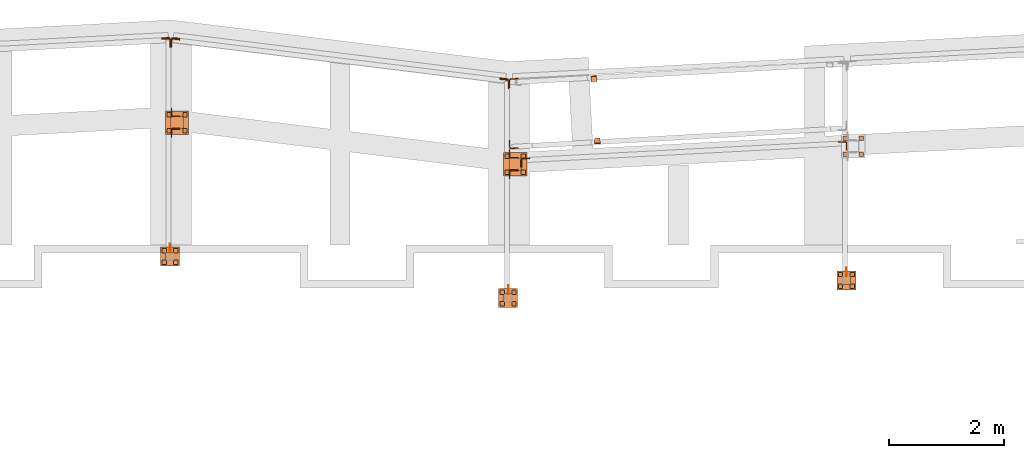
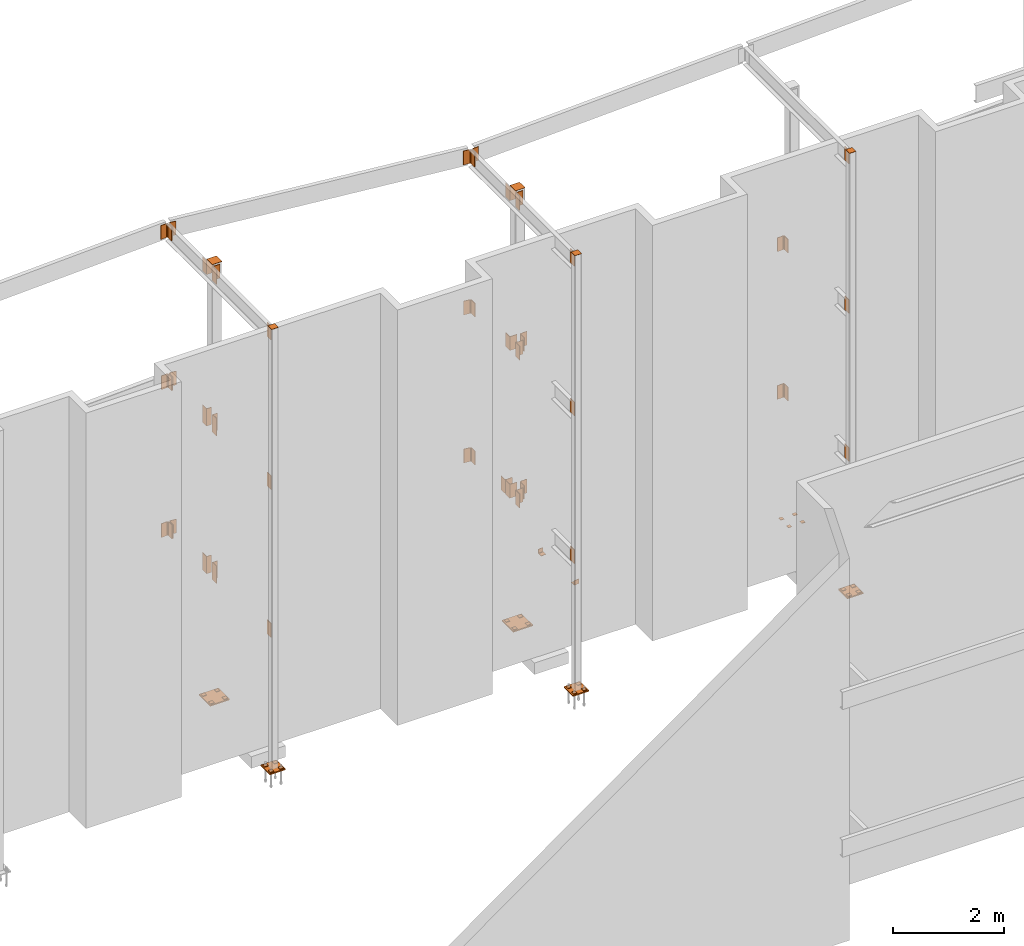
# One storey, part 9 of 89: 72 proxies.
"""IFC4 building model written with IfcOpenShell, lengths in feet."""

from ifc_helpers import new_model, entity, si_unit, converted_unit, derived_unit, direction, frame, origin, origin_2d_with_axis, place, context, subcontext, project, spatial, polyline, rectangle, outline, extrude, source, transform, mapped, material, type_object, type_shapes, element, save


model = new_model("IFC4")

# Units and contexts
model_context = context("Model", 3, precision=0.0001, world=origin(), true_north=direction((6.12303176911189e-17, 1.0)))
body_context = subcontext(model_context, "Body", "Model", "MODEL_VIEW")
ifc_project = project(units=[converted_unit("LENGTHUNIT", "FOOT", entity("IfcRatioMeasure", 0.3048), si_unit("LENGTHUNIT", "METRE"), dimensions=[1, 0, 0, 0, 0, 0, 0]), converted_unit("AREAUNIT", "SQUARE FOOT", entity("IfcRatioMeasure", 0.09290304), si_unit("AREAUNIT", "SQUARE_METRE"), dimensions=[2, 0, 0, 0, 0, 0, 0]), converted_unit("VOLUMEUNIT", "CUBIC FOOT", entity("IfcRatioMeasure", 0.028316846592), si_unit("VOLUMEUNIT", "CUBIC_METRE"), dimensions=[3, 0, 0, 0, 0, 0, 0]), si_unit("PLANEANGLEUNIT", "RADIAN"), si_unit("MASSUNIT", "GRAM", prefix="KILO"), derived_unit("MASSDENSITYUNIT", [(si_unit("MASSUNIT", "GRAM", prefix="KILO"), 1), (si_unit("LENGTHUNIT", "METRE"), -3)]), derived_unit("MOMENTOFINERTIAUNIT", [(si_unit("LENGTHUNIT", "METRE"), 4)]), si_unit("TIMEUNIT", "SECOND"), si_unit("FREQUENCYUNIT", "HERTZ"), si_unit("THERMODYNAMICTEMPERATUREUNIT", "DEGREE_CELSIUS"), derived_unit("THERMALTRANSMITTANCEUNIT", [(si_unit("MASSUNIT", "GRAM", prefix="KILO"), 1), (si_unit("THERMODYNAMICTEMPERATUREUNIT", "KELVIN"), -1), (si_unit("TIMEUNIT", "SECOND"), -3)]), derived_unit("VOLUMETRICFLOWRATEUNIT", [(si_unit("LENGTHUNIT", "METRE"), 3), (si_unit("TIMEUNIT", "SECOND"), -1)]), si_unit("ELECTRICCURRENTUNIT", "AMPERE"), si_unit("ELECTRICVOLTAGEUNIT", "VOLT"), si_unit("POWERUNIT", "WATT"), si_unit("FORCEUNIT", "NEWTON"), si_unit("ILLUMINANCEUNIT", "LUX"), si_unit("LUMINOUSFLUXUNIT", "LUMEN"), si_unit("LUMINOUSINTENSITYUNIT", "CANDELA"), derived_unit("USERDEFINED", [(si_unit("MASSUNIT", "GRAM", prefix="KILO"), -1), (si_unit("LENGTHUNIT", "METRE"), -2), (si_unit("TIMEUNIT", "SECOND"), 3), (si_unit("LUMINOUSFLUXUNIT", "LUMEN"), 1)]), derived_unit("LINEARVELOCITYUNIT", [(si_unit("LENGTHUNIT", "METRE"), 1), (si_unit("TIMEUNIT", "SECOND"), -1)]), si_unit("PRESSUREUNIT", "PASCAL"), derived_unit("USERDEFINED", [(si_unit("LENGTHUNIT", "METRE"), -2), (si_unit("MASSUNIT", "GRAM", prefix="KILO"), 1), (si_unit("TIMEUNIT", "SECOND"), -2)]), derived_unit("LINEARFORCEUNIT", [(si_unit("MASSUNIT", "GRAM", prefix="KILO"), 1), (si_unit("LENGTHUNIT", "METRE"), 1), (si_unit("TIMEUNIT", "SECOND"), -2), (si_unit("LENGTHUNIT", "METRE"), -1)]), derived_unit("PLANARFORCEUNIT", [(si_unit("MASSUNIT", "GRAM", prefix="KILO"), 1), (si_unit("LENGTHUNIT", "METRE"), 1), (si_unit("TIMEUNIT", "SECOND"), -2), (si_unit("LENGTHUNIT", "METRE"), -2)])], contexts=[model_context])

# Site, building, storey
site_placement = place(None, origin())
site = spatial("IfcSite", under=ifc_project, at=site_placement, CompositionType="ELEMENT")
building_placement = place(site_placement, frame((-472.238160486, -49.138065117, 0.0)))
building = spatial("IfcBuilding", under=site, at=building_placement, CompositionType="ELEMENT")
storey_placement = place(building_placement, origin())
storey = spatial("IfcBuildingStorey", under=building, at=storey_placement, Name="Level 1", CompositionType="ELEMENT", Elevation=0.0)

# Proxies
ifc_material_1 = material(Name="Color 7722", Category="Materials")
building_element_proxy_type_1 = type_object("IfcBuildingElementProxyType", Name="MATERIAL 9060:MATERIAL 9060", PredefinedType="NOTDEFINED", material=ifc_material_1)
shared_shape_1 = source(origin(), body_context, "Body", "SweptSolid", [
    extrude(rectangle(XDim=0.25, YDim=0.25, at=origin_2d_with_axis()), frame((0.125, -0.125, 0.0)), (0.0, 0.0, 1.0), 0.03125),
])
type_shapes(building_element_proxy_type_1, [shared_shape_1])
for number, where, z_axis, x_axis, name in (
    (1, (307.583333333333, 1014.21875, -0.385416666666667), (0.0, 0.0, -1.0), (0.0, -1.0, 0.0), "PW1"),
    (2, (308.5, 1014.21875, -0.385416666666667), (0.0, 0.0, -1.0), (0.0, -1.0, 0.0), "PW1"),
    (3, (308.5, 1013.30208333333, -0.385416666666667), (0.0, 0.0, -1.0), (0.0, -1.0, 0.0), "PW1"),
    (4, (307.3125, 1006.4375, -0.677083333333333), (0.0, 0.0, -1.0), (0.0, -1.0, 0.0), "PW1"),
    (5, (307.979166666667, 1006.4375, -0.677083333333333), (0.0, 0.0, -1.0), (0.0, -1.0, 0.0), "PW1"),
    (6, (307.979166666667, 1005.77083333333, -0.677083333333333), (0.0, 0.0, -1.0), (0.0, -1.0, 0.0), "PW1"),
    (7, (287.979166666667, 1005.421875, -0.34375), (0.0, 0.0, -1.0), (0.0, -1.0, 0.0), "PW1"),
    (8, (288.645833333333, 1005.421875, -0.34375), (0.0, 0.0, -1.0), (0.0, -1.0, 0.0), "PW1"),
    (9, (288.645833333333, 1004.75520833333, -0.34375), (0.0, 0.0, -1.0), (0.0, -1.0, 0.0), "PW1"),
    (10, (288.25, 1013.203125, -0.364583333333333), (0.0, 0.0, -1.0), (0.0, -1.0, 0.0), "PW1"),
    (11, (289.166666666667, 1013.203125, -0.364583333333333), (0.0, 0.0, -1.0), (0.0, -1.0, 0.0), "PW1"),
    (12, (289.166666666667, 1012.28645833333, -0.364583333333333), (0.0, 0.0, -1.0), (0.0, -1.0, 0.0), "PW1"),
    (13, (268.645833333333, 1007.796875, -0.677083333333333), (0.0, 0.0, -1.0), (0.0, -1.0, 0.0), "PW1"),
    (14, (269.3125, 1007.796875, -0.677083333333333), (0.0, 0.0, -1.0), (0.0, -1.0, 0.0), "PW1"),
    (15, (269.3125, 1007.13020833333, -0.677083333333333), (0.0, 0.0, -1.0), (0.0, -1.0, 0.0), "PW1"),
    (16, (268.916666666667, 1015.578125, -0.385416666666667), (0.0, 0.0, -1.0), (0.0, -1.0, 0.0), "PW1"),
    (17, (269.833333333333, 1015.578125, -0.385416666666667), (0.0, 0.0, -1.0), (0.0, -1.0, 0.0), "PW1"),
    (18, (269.833333333333, 1014.66145833333, -0.385416666666667), (0.0, 0.0, -1.0), (0.0, -1.0, 0.0), "PW1"),
    (19, (307.3125, 1005.77083333333, -0.677083333333333), (0.0, 0.0, -1.0), (0.0, -1.0, 0.0), "PW1"),
    (20, (307.583333333333, 1013.30208333333, -0.385416666666667), (0.0, 0.0, -1.0), (0.0, -1.0, 0.0), "PW1"),
    (21, (287.979166666667, 1004.75520833333, -0.34375), (0.0, 0.0, -1.0), (0.0, -1.0, 0.0), "PW1"),
    (22, (288.25, 1012.28645833333, -0.364583333333333), (0.0, 0.0, -1.0), (0.0, -1.0, 0.0), "PW1"),
    (23, (268.645833333333, 1007.13020833333, -0.677083333333333), (0.0, 0.0, -1.0), (0.0, -1.0, 0.0), "PW1"),
    (24, (268.916666666667, 1014.66145833333, -0.385416666666667), (0.0, 0.0, -1.0), (0.0, -1.0, 0.0), "PW1"),
):
    element("IfcBuildingElementProxy", number, at=place(building_placement, frame(where, z_axis=z_axis, x_axis=x_axis)), inside=storey, type_object=building_element_proxy_type_1, material=ifc_material_1, Name=name, ObjectType="MATERIAL", PredefinedType="NOTDEFINED", context=body_context, shape_type="MappedRepresentation", body=[
        mapped(shared_shape_1, transform((0.0, 0.0, 0.0), scale=1.0)),
    ])
ifc_material_2 = material(Name="Color 7718", Category="Materials")
building_element_proxy_type_2 = type_object("IfcBuildingElementProxyType", Name="MATERIAL 9713:MATERIAL 9713", PredefinedType="NOTDEFINED", material=ifc_material_2)
shared_shape_2 = source(origin(), body_context, "Body", "SweptSolid", [
    extrude(outline(polyline([(-0.0916239487102203, -0.241709384623146), (-0.0603739487102203, -0.241709384623146), (-0.0603739487102203, 0.0291239487101845), (-0.0579951841011973, 0.0410828059715835), (-0.0512210356222993, 0.0512210356223565), (-0.0410828059716293, 0.0579951841011865), (-0.0291239487102203, 0.0603739487102815), (0.241709384623114, 0.0603739487102815), (0.241709384623114, 0.0916239487102095), (-0.0916239487102203, 0.0916239487102095), (-0.0916239487102203, -0.241709384623146)])), frame((0.0, -0.0916239487102203, 0.0916239487102095), z_axis=(1.0, 0.0, 0.0), x_axis=(0.0, -1.0, 0.0)), (0.0, 0.0, 1.0), 0.333333333333366),
])
type_shapes(building_element_proxy_type_2, [shared_shape_2])
for number, where, z_axis, x_axis, name in (
    (25, (293.377121530219, 1013.7658318413, 0.0), (-0.0556972760759885, 0.998447701904168, 0.0), (0.998447701904168, 0.055697276075988, 0.0), "a17"),
    (26, (293.492285442201, 1017.68249264928, 0.0), (0.0556972760759748, -0.998447701904169, 0.0), (-0.998447701904169, -0.0556972760759755, 0.0), "a17"),
):
    element("IfcBuildingElementProxy", number, at=place(building_placement, frame(where, z_axis=z_axis, x_axis=x_axis)), inside=storey, type_object=building_element_proxy_type_2, material=ifc_material_2, Name=name, ObjectType="MATERIAL", PredefinedType="NOTDEFINED", context=body_context, shape_type="MappedRepresentation", body=[
        mapped(shared_shape_2, transform((0.0, 0.0, 0.0), scale=1.0)),
    ])
building_element_proxy_type_3 = type_object("IfcBuildingElementProxyType", Name="MATERIAL 9158:MATERIAL 9158", PredefinedType="NOTDEFINED", material=ifc_material_2)
shared_shape_3 = source(origin(), body_context, "Body", "SweptSolid", [
    extrude(outline(polyline([(0.0111715792294897, -0.0976026118399068), (0.407378579745101, -0.0976026118399068), (0.407378579745101, -0.0611442785065728), (0.0111715792294897, -0.0611442785065728), (-0.00708529606607824, -0.0588217106174638), (-0.0241791222467533, -0.0520019654854818), (-0.0390209419147643, -0.0411194930595618), (-0.0506652611151263, -0.0268675581902408), (-0.0583702817624623, -0.0101540763871088), (-0.0616451576796762, 0.00795622468403817), (-0.0823810299218372, 0.403620237275397), (-0.118789398376419, 0.401712155537369), (-0.0980535261342592, 0.00604814294601114), (-0.0931412122585143, -0.0211173086606718), (-0.0815836812875102, -0.0461875313654078), (-0.0641172024869673, -0.0675654336693708), (-0.0418544729849502, -0.0838891423082878), (-0.0162137337138623, -0.0941187600062608), (0.0111715792294897, -0.0976026118399068)])), frame((0.0, -0.0926214202548993, -0.0976026118399068), z_axis=(1.0, 0.0, 0.0), x_axis=(0.0, -1.0, 0.0)), (0.0, 0.0, 1.0), 1.0),
])
type_shapes(building_element_proxy_type_3, [shared_shape_3])
for number, where, z_axis, x_axis, name in (
    (27, (288.5, 1017.50123639763, 29.9583333333333), (-1.0, 0.0, 0.0), (0.0, 0.0, 1.0), "p59"),
    (28, (289.166666666667, 1012.94773549414, 19.1458333333333), (-1.0, 0.0, 0.0), (0.0, 0.0, 1.0), "p61"),
    (29, (289.166666666667, 1012.94773549414, 8.47916666666667), (-1.0, 0.0, 0.0), (0.0, 0.0, 1.0), "p61"),
):
    element("IfcBuildingElementProxy", number, at=place(building_placement, frame(where, z_axis=z_axis, x_axis=x_axis)), inside=storey, type_object=building_element_proxy_type_3, material=ifc_material_2, Name=name, ObjectType="MATERIAL", PredefinedType="NOTDEFINED", context=body_context, shape_type="MappedRepresentation", body=[
        mapped(shared_shape_3, transform((0.0, 0.0, 0.0), scale=1.0)),
    ])
building_element_proxy_type_4 = type_object("IfcBuildingElementProxyType", Name="MATERIAL 9508:MATERIAL 9508", PredefinedType="NOTDEFINED", material=ifc_material_2)
shared_shape_4 = source(origin(), body_context, "Body", "SweptSolid", [
    extrude(outline(polyline([(0.00933795100327561, -0.100513615372161), (0.394080749800685, -0.100513615372161), (0.394080749800685, -0.0640552820388279), (0.00933795100327567, -0.0640552820388279), (-0.0101481805857443, -0.0614033359186079), (-0.0282169086254994, -0.0536403977150289), (-0.0435539302164183, -0.0413311365164909), (-0.0550436443093494, -0.0253709168252909), (-0.0618502995158724, -0.0069206705551659), (-0.0634787859058903, 0.0126775481038942), (-0.0433429036232124, 0.396893070267087), (-0.0797512720777954, 0.398801152005115), (-0.0998871543604734, 0.0145856298419221), (-0.0974444247755213, -0.0148116981466309), (-0.0872344419656624, -0.0424870675518559), (-0.0699998708261134, -0.0664273970886559), (-0.0469943384400384, -0.0848912888864439), (-0.0198912463803294, -0.0965356961918699), (0.00933795100327561, -0.100513615372161)])), frame((0.0, 0.394080749800685, 0.398801152005115), z_axis=(1.0, 0.0, 0.0), x_axis=(0.0, -1.0, 0.0)), (0.0, 0.0, 1.0), 1.0),
])
type_shapes(building_element_proxy_type_4, [shared_shape_4])
for number, where, z_axis, x_axis, name in (
    (30, (288.973096906464, 1014.0218171543, 8.47916666666667), (0.0556972760760702, -0.998447701904164, 0.0), (0.0, 0.0, 1.0), "p60"),
    (31, (268.634018565956, 1019.31016434794, 9.47916666666667), (1.0, 0.0, 0.0), (0.0, 0.0, -1.0), "p62"),
    (32, (307.32681734844, 1013.39860140302, 19.1458333333333), (-0.0523359562429422, 0.998629534754574, 0.0), (0.0, 0.0, 1.0), "p60"),
    (33, (307.32681734844, 1013.39860140302, 8.47916666666667), (-0.0523359562429422, 0.998629534754574, 0.0), (0.0, 0.0, 1.0), "p60"),
):
    element("IfcBuildingElementProxy", number, at=place(building_placement, frame(where, z_axis=z_axis, x_axis=x_axis)), inside=storey, type_object=building_element_proxy_type_4, material=ifc_material_2, Name=name, ObjectType="MATERIAL", PredefinedType="NOTDEFINED", context=body_context, shape_type="MappedRepresentation", body=[
        mapped(shared_shape_4, transform((0.0, 0.0, 0.0), scale=1.0)),
    ])
building_element_proxy_type_5 = type_object("IfcBuildingElementProxyType", Name="CONNECTION MATERIAL 9087:CONNECTION MATERIAL 9087", PredefinedType="NOTDEFINED", material=ifc_material_2)
shared_shape_5 = source(origin(), body_context, "Body", "SweptSolid", [
    extrude(rectangle(XDim=0.458333333333333, YDim=0.458333333333333, at=origin_2d_with_axis()), frame((0.0, 0.0, -0.0208333333333333)), (0.0, 0.0, 1.0), 0.0208333333333333),
])
type_shapes(building_element_proxy_type_5, [shared_shape_5])
for number, where, z_axis, x_axis, name in (
    (34, (307.770833333333, 1005.97916666667, 31.0625), (0.0, 0.0, -1.0), (1.0, 0.0, 0.0), "cp2"),
    (35, (288.4375, 1004.96354166667, 31.0625), (0.0, 0.0, -1.0), (1.0, 0.0, 0.0), "cp2"),
    (36, (269.104166666667, 1007.33854166667, 31.0625), (0.0, 0.0, -1.0), (1.0, 0.0, 0.0), "cp2"),
):
    element("IfcBuildingElementProxy", number, at=place(building_placement, frame(where, z_axis=z_axis, x_axis=x_axis)), inside=storey, type_object=building_element_proxy_type_5, material=ifc_material_2, Name=name, ObjectType="CONNECTION MATERIAL", PredefinedType="NOTDEFINED", context=body_context, shape_type="MappedRepresentation", body=[
        mapped(shared_shape_5, transform((0.0, 0.0, 0.0), scale=1.0)),
    ])
building_element_proxy_type_6 = type_object("IfcBuildingElementProxyType", Name="CONNECTION MATERIAL 9070:CONNECTION MATERIAL 9070", PredefinedType="NOTDEFINED", material=ifc_material_2)
shared_shape_6 = source(origin(), body_context, "Body", "SweptSolid", [
    extrude(rectangle(XDim=1.08333333333333, YDim=1.08333333333333, at=origin_2d_with_axis()), frame((0.0, 0.0, -0.0833333333333333)), (0.0, 0.0, 1.0), 0.0833333333333333),
])
type_shapes(building_element_proxy_type_6, [shared_shape_6])
for number, where, name in (
    (37, (307.770833333333, 1005.97916666667, -0.708333333333333), "bp1"),
    (38, (288.4375, 1004.96354166667, -0.375), "bp1"),
    (39, (269.104166666667, 1007.33854166667, -0.708333333333333), "bp1"),
):
    element("IfcBuildingElementProxy", number, at=place(building_placement, frame(where)), inside=storey, type_object=building_element_proxy_type_6, material=ifc_material_2, Name=name, ObjectType="CONNECTION MATERIAL", PredefinedType="NOTDEFINED", context=body_context, shape_type="MappedRepresentation", body=[
        mapped(shared_shape_6, transform((0.0, 0.0, 0.0), scale=1.0)),
    ])
building_element_proxy_type_7 = type_object("IfcBuildingElementProxyType", Name="MATERIAL 9674:MATERIAL 9674", PredefinedType="NOTDEFINED", material=ifc_material_2)
shared_shape_7 = source(origin(), body_context, "Body", "SweptSolid", [
    extrude(outline(polyline([(0.00927777719940995, -0.100601442241298), (0.393616957598169, -0.100601442241298), (0.393616957598169, -0.0641431089079642), (0.00927777719940995, -0.0641431089079642), (-0.0102492294469511, -0.0614798143255262), (-0.02834978111711, -0.0536844852214712), (-0.043701625892178, -0.0413265732374542), (-0.0551833058974201, -0.0253088283630792), (-0.0619560802097111, -0.00680135271898923), (-0.0635251951888071, 0.0128438758311247), (-0.0420708037111881, 0.396583780813474), (-0.0784722899052211, 0.398618939849704), (-0.099926681382991, 0.0148790348673168), (-0.097573008914272, -0.0145888079578152), (-0.0874138474458351, -0.0423500214240082), (-0.070191327438048, -0.0663766387355142), (-0.047163560275294, -0.0849135067115572), (-0.0200127327701311, -0.0966065003676792), (0.00927777719940995, -0.100601442241298)])), frame((0.0, 0.393616957598169, 0.398618939849704), z_axis=(1.0, 0.0, 0.0), x_axis=(0.0, -1.0, 0.0)), (0.0, 0.0, 1.0), 1.0),
])
type_shapes(building_element_proxy_type_7, [shared_shape_7])
proxy_1_placement = place(building_placement, frame((268.634112951242, 1019.37499999999, 30.9583333333333), z_axis=(1.0, 0.0, 0.0), x_axis=(0.0, 0.0, -1.0)))
element("IfcBuildingElementProxy", 40, at=proxy_1_placement, inside=storey, type_object=building_element_proxy_type_7, material=ifc_material_2, Name="p79", ObjectType="MATERIAL", PredefinedType="NOTDEFINED", context=body_context, shape_type="MappedRepresentation", body=[
    mapped(shared_shape_7, transform((0.0, 0.0, 0.0), scale=1.0)),
])
building_element_proxy_type_8 = type_object("IfcBuildingElementProxyType", Name="MATERIAL 9620:MATERIAL 9620", PredefinedType="NOTDEFINED", material=ifc_material_2)
shared_shape_8 = source(origin(), body_context, "Body", "SweptSolid", [
    extrude(outline(polyline([(0.013419301184293, -0.0975030902930638), (0.389793352676035, -0.0975030902930638), (0.389793352676035, -0.0610447569597307), (0.013419301184293, -0.0610447569597307), (-0.00404437764661902, -0.0589225830129327), (-0.020491527172976, -0.0526795890974507), (-0.0349647884309661, -0.0426791686497308), (-0.046621698939127, -0.0295034281400448), (-0.054783730922804, -0.0139193037030277), (-0.05895385570609, 0.00316608083420125), (-0.05895385570609, 0.0207582159968983), (-0.0130853971761481, 0.394326832382618), (-0.0492719756214151, 0.398769985527581), (-0.095173331384323, 0.0252013691418593), (-0.095173331384323, -0.00118683360216575), (-0.088885246976505, -0.0268149104080298), (-0.0766421990008361, -0.0501910970635738), (-0.059156833238596, -0.0699547078280447), (-0.037446941351762, -0.0849553384996627), (-0.012776217062075, -0.0943198293729058), (0.013419301184293, -0.0975030902930638)])), frame((0.0, 0.389793352676035, 0.398769985527581), z_axis=(1.0, 0.0, 0.0), x_axis=(0.0, -1.0, 0.0)), (0.0, 0.0, 1.0), 1.0),
])
type_shapes(building_element_proxy_type_8, [shared_shape_8])
for number, where, z_axis, x_axis, name in (
    (41, (269.662939742488, 1019.37499999999, 29.9583333333333), (-1.0, 0.0, 0.0), (0.0, 0.0, 1.0), "p64"),
    (42, (269.662939742488, 1019.34141434794, 19.1458333333333), (-1.0, 0.0, 0.0), (0.0, 0.0, 1.0), "p73"),
    (43, (269.662939742488, 1019.31016434794, 8.47916666666667), (-1.0, 0.0, 0.0), (0.0, 0.0, 1.0), "p64"),
):
    element("IfcBuildingElementProxy", number, at=place(building_placement, frame(where, z_axis=z_axis, x_axis=x_axis)), inside=storey, type_object=building_element_proxy_type_8, material=ifc_material_2, Name=name, ObjectType="MATERIAL", PredefinedType="NOTDEFINED", context=body_context, shape_type="MappedRepresentation", body=[
        mapped(shared_shape_8, transform((0.0, 0.0, 0.0), scale=1.0)),
    ])
building_element_proxy_type_9 = type_object("IfcBuildingElementProxyType", Name="MATERIAL 9617:MATERIAL 9617", PredefinedType="NOTDEFINED", material=ifc_material_2)
shared_shape_9 = source(origin(), body_context, "Body", "SweptSolid", [
    extrude(outline(polyline([(0.0123891797244242, -0.0953715797058789), (0.415622353913578, -0.0953715797058789), (0.415622353913578, -0.0589132463725448), (0.0123891797244242, -0.0589132463725449), (-0.00504507862362676, -0.0567983234247439), (-0.0214679875849068, -0.0505762398131349), (-0.0359268654579458, -0.0406079343467619), (-0.0475829626398587, -0.0274716615987809), (-0.0557601169156338, -0.0119294477548809), (-0.0599839771661107, 0.00511711400415997), (-0.109125739343704, 0.405344649259765), (-0.145312317788972, 0.400901496114765), (-0.0961705556113788, 0.000673960859198103), (-0.0898347652355878, -0.0248958817793629), (-0.0775690338219248, -0.0482092025452519), (-0.0600848880492068, -0.0679136116671659), (-0.0383965712394958, -0.0828660698667629), (-0.0137622077976528, -0.0921991952841949), (0.0123891797244242, -0.0953715797058789)])), frame((0.0, -0.0843776460864217, -0.0953715797058789), z_axis=(1.0, 0.0, 0.0), x_axis=(0.0, -1.0, 0.0)), (0.0, 0.0, 1.0), 1.0),
])
type_shapes(building_element_proxy_type_9, [shared_shape_9])
for number, where, z_axis, x_axis, name in (
    (44, (288.466666666667, 1017.50123639763, 30.9583333333333), (1.0, 0.0, 0.0), (0.0, 0.0, -1.0), "p81"),
    (45, (288.466666666667, 1017.46991515588, 20.1458333333333), (1.0, 0.0, 0.0), (0.0, 0.0, -1.0), "p69"),
):
    element("IfcBuildingElementProxy", number, at=place(building_placement, frame(where, z_axis=z_axis, x_axis=x_axis)), inside=storey, type_object=building_element_proxy_type_9, material=ifc_material_2, Name=name, ObjectType="MATERIAL", PredefinedType="NOTDEFINED", context=body_context, shape_type="MappedRepresentation", body=[
        mapped(shared_shape_9, transform((0.0, 0.0, 0.0), scale=1.0)),
    ])
building_element_proxy_type_10 = type_object("IfcBuildingElementProxyType", Name="MATERIAL:MATERIAL", PredefinedType="NOTDEFINED", material=ifc_material_2)
shared_shape_10 = source(origin(), body_context, "Body", "SweptSolid", [
    extrude(outline(polyline([(-0.130151376058071, -0.130151376058075), (0.369848623941929, -0.130151376058075), (0.369848623941929, -0.0936930427247416), (-0.0520263760580709, -0.0936930427247416), (-0.0679715190732959, -0.0905213565793626), (-0.0814891586075149, -0.0814891586074436), (-0.0905213565793589, -0.0679715190733376), (-0.0936930427247379, -0.0520263760580746), (-0.0936930427247379, 0.369848623941925), (-0.130151376058071, 0.369848623941925), (-0.130151376058071, -0.130151376058075)])), frame((0.0, -0.130151376058071, -0.130151376058075), z_axis=(1.0, 0.0, 0.0), x_axis=(0.0, -1.0, 0.0)), (0.0, 0.0, 1.0), 1.0),
])
type_shapes(building_element_proxy_type_10, [shared_shape_10])
for number, where, z_axis, x_axis, name in (
    (46, (269.166666666667, 1015.328125, 30.9583333333333), (-1.0, 0.0, 0.0), (0.0, 0.0, -1.0), "a15"),
    (47, (269.166666666667, 1014.66145833333, 30.9583333333333), (0.0, 1.0, 0.0), (0.0, 0.0, -1.0), "a15"),
    (48, (288.5, 1012.953125, 30.9583333333333), (-1.0, 0.0, 0.0), (0.0, 0.0, -1.0), "a15"),
    (49, (288.5, 1012.28645833333, 30.9583333333333), (0.0, 1.0, 0.0), (0.0, 0.0, -1.0), "a15"),
    (50, (288.5, 1012.953125, 20.1458333333333), (-1.0, 0.0, 0.0), (0.0, 0.0, -1.0), "a15"),
    (51, (288.5, 1012.28645833333, 20.1458333333333), (0.0, 1.0, 0.0), (0.0, 0.0, -1.0), "a15"),
    (52, (288.5, 1012.953125, 9.47916666666667), (-1.0, 0.0, 0.0), (0.0, 0.0, -1.0), "a15"),
    (53, (288.5, 1012.28645833333, 9.47916666666667), (0.0, 1.0, 0.0), (0.0, 0.0, -1.0), "a15"),
):
    element("IfcBuildingElementProxy", number, at=place(building_placement, frame(where, z_axis=z_axis, x_axis=x_axis)), inside=storey, type_object=building_element_proxy_type_10, material=ifc_material_2, Name=name, ObjectType="MATERIAL", PredefinedType="NOTDEFINED", context=body_context, shape_type="MappedRepresentation", body=[
        mapped(shared_shape_10, transform((0.0, 0.0, 0.0), scale=1.0)),
    ])
building_element_proxy_type_11 = type_object("IfcBuildingElementProxyType", Name="MATERIAL 9626:MATERIAL 9626", PredefinedType="NOTDEFINED", material=ifc_material_2)
shared_shape_11 = source(origin(), body_context, "Body", "SweptSolid", [
    extrude(outline(polyline([(0.0122314695217939, -0.100513615372161), (0.370932601652536, -0.100513615372161), (0.370932601652536, -0.0640552820388278), (0.0122314695217939, -0.0640552820388278), (-0.00725466206722514, -0.0614033359186079), (-0.0253233901069811, -0.0536403977150289), (-0.0406604116979001, -0.0413311365164909), (-0.0521501257908311, -0.0253709168252909), (-0.0589567809973531, -0.00692067055516589), (-0.0605852673873721, 0.0126775481038942), (-0.0404493851046931, 0.396893070267087), (-0.0768577535592761, 0.398801152005115), (-0.0969936358419541, 0.0145856298419221), (-0.0945509062570031, -0.0148116981466309), (-0.0843409234471441, -0.0424870675518559), (-0.0671063523075951, -0.0664273970886559), (-0.0441008199215201, -0.0848912888864439), (-0.0169977278618111, -0.0965356961918699), (0.0122314695217939, -0.100513615372161)])), frame((0.0, 0.370932601652536, 0.398801152005115), z_axis=(1.0, 0.0, 0.0), x_axis=(0.0, -1.0, 0.0)), (0.0, 0.0, 1.0), 1.0),
])
type_shapes(building_element_proxy_type_11, [shared_shape_11])
proxy_2_placement = place(building_placement, frame((268.634018565956, 1019.34141434794, 20.1458333333333), z_axis=(1.0, 0.0, 0.0), x_axis=(0.0, 0.0, -1.0)))
element("IfcBuildingElementProxy", 54, at=proxy_2_placement, inside=storey, type_object=building_element_proxy_type_11, material=ifc_material_2, Name="p72", ObjectType="MATERIAL", PredefinedType="NOTDEFINED", context=body_context, shape_type="MappedRepresentation", body=[
    mapped(shared_shape_11, transform((0.0, 0.0, 0.0), scale=1.0)),
])
building_element_proxy_type_12 = type_object("IfcBuildingElementProxyType", Name="MATERIAL 9611:MATERIAL 9611", PredefinedType="NOTDEFINED", material=ifc_material_2)
shared_shape_12 = source(origin(), body_context, "Body", "SweptSolid", [
    extrude(outline(polyline([(0.0125391829034624, -0.0950768022346421), (0.416619882263603, -0.0950768022346421), (0.416619882263603, -0.0586184689013081), (0.0125391829034624, -0.0586184689013081), (-0.00479208007861155, -0.0565288281585081), (-0.0211299868116535, -0.0503796754872281), (-0.0355381161142155, -0.0405234548633171), (-0.0471906536593755, -0.0275250840519051), (-0.0554197242317965, -0.0121295758594881), (-0.0597536715717975, 0.00478066291596897), (-0.112496786608821, 0.40540439587695), (-0.148643213846451, 0.400645628452255), (-0.0959000988092766, 2.18954912748621e-05), (-0.0893991777993505, -0.0253434626719101), (-0.0770555719406425, -0.0484367249605361), (-0.0595767656232055, -0.0679342811776731), (-0.0379645716692115, -0.0827186121135031), (-0.0134577115697235, -0.0919423411204791), (0.0125391829034624, -0.0950768022346421)])), frame((0.0, -0.0833801177363965, -0.0950768022346421), z_axis=(1.0, 0.0, 0.0), x_axis=(0.0, -1.0, 0.0)), (0.0, 0.0, 1.0), 1.0),
])
type_shapes(building_element_proxy_type_12, [shared_shape_12])
proxy_3_placement = place(building_placement, frame((288.466666666667, 1017.43824567004, 9.47916666666667), z_axis=(1.0, 0.0, 0.0), x_axis=(0.0, 0.0, -1.0)))
element("IfcBuildingElementProxy", 55, at=proxy_3_placement, inside=storey, type_object=building_element_proxy_type_12, material=ifc_material_2, Name="p67", ObjectType="MATERIAL", PredefinedType="NOTDEFINED", context=body_context, shape_type="MappedRepresentation", body=[
    mapped(shared_shape_12, transform((0.0, 0.0, 0.0), scale=1.0)),
])
building_element_proxy_type_13 = type_object("IfcBuildingElementProxyType", Name="CONNECTION MATERIAL 9054:CONNECTION MATERIAL 9054", PredefinedType="NOTDEFINED", material=ifc_material_2)
shared_shape_13 = source(origin(), body_context, "Body", "SweptSolid", [
    extrude(rectangle(XDim=0.666666666666667, YDim=0.666666666666667, at=origin_2d_with_axis()), frame((0.0, 0.0, -0.0208333333333333)), (0.0, 0.0, 1.0), 0.0208333333333333),
])
type_shapes(building_element_proxy_type_13, [shared_shape_13])
for number, where, z_axis, x_axis, name in (
    (56, (269.5, 1014.99479166667, 31.0625), (0.0, 0.0, -1.0), (1.0, 0.0, 0.0), "cp1"),
    (57, (288.833333333333, 1012.61979166667, 31.0625), (0.0, 0.0, -1.0), (1.0, 0.0, 0.0), "cp1"),
):
    element("IfcBuildingElementProxy", number, at=place(building_placement, frame(where, z_axis=z_axis, x_axis=x_axis)), inside=storey, type_object=building_element_proxy_type_13, material=ifc_material_2, Name=name, ObjectType="CONNECTION MATERIAL", PredefinedType="NOTDEFINED", context=body_context, shape_type="MappedRepresentation", body=[
        mapped(shared_shape_13, transform((0.0, 0.0, 0.0), scale=1.0)),
    ])
building_element_proxy_type_14 = type_object("IfcBuildingElementProxyType", Name="CONNECTION MATERIAL:CONNECTION MATERIAL", PredefinedType="NOTDEFINED", material=ifc_material_2)
shared_shape_14 = source(origin(), body_context, "Body", "SweptSolid", [
    extrude(rectangle(XDim=1.33333333333333, YDim=1.33333333333333, at=origin_2d_with_axis()), frame((0.0, 0.0, -0.0833333333333333)), (0.0, 0.0, 1.0), 0.0833333333333333),
])
type_shapes(building_element_proxy_type_14, [shared_shape_14])
for number, where, name in (
    (58, (269.5, 1014.99479166667, -0.416666666666667), "bp2"),
    (59, (288.833333333333, 1012.61979166667, -0.395833333333333), "bp2"),
):
    element("IfcBuildingElementProxy", number, at=place(building_placement, frame(where)), inside=storey, type_object=building_element_proxy_type_14, material=ifc_material_2, Name=name, ObjectType="CONNECTION MATERIAL", PredefinedType="NOTDEFINED", context=body_context, shape_type="MappedRepresentation", body=[
        mapped(shared_shape_14, transform((0.0, 0.0, 0.0), scale=1.0)),
    ])
ifc_material_3 = material(Name="Color", Category="Materials")
building_element_proxy_type_15 = type_object("IfcBuildingElementProxyType", Name="MATERIAL 9165:MATERIAL 9165", PredefinedType="NOTDEFINED", material=ifc_material_3)
shared_shape_15 = source(origin(), body_context, "Body", "SweptSolid", [
    extrude(outline(polyline([(-0.130151376058075, -0.0968180427247379), (0.369848623941925, -0.0968180427247379), (0.369848623941925, -0.0603597093914039), (-0.0520263760580746, -0.0603597093914039), (-0.0679715190733376, -0.0571880232460259), (-0.0814891586074436, -0.0481558252741819), (-0.0905213565793626, -0.034638185739963), (-0.0936930427247416, -0.0186930427247376), (-0.0936930427247416, 0.236515290608596), (-0.130151376058075, 0.236515290608596), (-0.130151376058075, -0.0968180427247379)])), frame((0.0, -0.130151376058075, -0.0968180427247379), z_axis=(1.0, 0.0, 0.0), x_axis=(0.0, -1.0, 0.0)), (0.0, 0.0, 1.0), 1.25),
])
type_shapes(building_element_proxy_type_15, [shared_shape_15])
for number, where, z_axis, x_axis, name in (
    (60, (269.166666666667, 1015.328125, 20.2708333333333), (-1.0, 0.0, 0.0), (0.0, 0.0, -1.0), "a6"),
    (61, (269.166666666667, 1014.66145833333, 19.0208333333333), (-1.0, 0.0, 0.0), (0.0, 0.0, 1.0), "a6"),
    (62, (269.166666666667, 1015.328125, 9.60416666666667), (-1.0, 0.0, 0.0), (0.0, 0.0, -1.0), "a6"),
    (63, (269.166666666667, 1014.66145833333, 8.35416666666667), (-1.0, 0.0, 0.0), (0.0, 0.0, 1.0), "a6"),
):
    element("IfcBuildingElementProxy", number, at=place(building_placement, frame(where, z_axis=z_axis, x_axis=x_axis)), inside=storey, type_object=building_element_proxy_type_15, material=ifc_material_3, Name=name, ObjectType="MATERIAL", PredefinedType="NOTDEFINED", context=body_context, shape_type="MappedRepresentation", body=[
        mapped(shared_shape_15, transform((0.0, 0.0, 0.0), scale=1.0)),
    ])
building_element_proxy_type_16 = type_object("IfcBuildingElementProxyType", Name="MATERIAL 9089:MATERIAL 9089", PredefinedType="NOTDEFINED", material=ifc_material_2)
shared_shape_16 = source(origin(), body_context, "Body", "SweptSolid", [
    extrude(rectangle(XDim=1.0, YDim=0.5, at=origin_2d_with_axis()), frame((0.5, -0.25, 0.0)), (0.0, 0.0, 1.0), 0.0364583333333333),
])
type_shapes(building_element_proxy_type_16, [shared_shape_16])
for number, where, z_axis, x_axis, name in (
    (64, (307.8, 1006.20833333333, 30.9583333333333), (-1.0, 0.0, 0.0), (0.0, 0.0, -1.0), "p21"),
    (65, (307.8, 1006.20833333333, 20.1458333333333), (-1.0, 0.0, 0.0), (0.0, 0.0, -1.0), "p21"),
    (66, (307.8, 1006.20833333333, 9.47916666666667), (-1.0, 0.0, 0.0), (0.0, 0.0, -1.0), "p21"),
    (67, (288.466666666667, 1005.19270833333, 30.9583333333333), (-1.0, 0.0, 0.0), (0.0, 0.0, -1.0), "p21"),
    (68, (288.466666666667, 1005.19270833333, 20.1458333333333), (-1.0, 0.0, 0.0), (0.0, 0.0, -1.0), "p21"),
    (69, (288.466666666667, 1005.19270833333, 9.47916666666667), (-1.0, 0.0, 0.0), (0.0, 0.0, -1.0), "p21"),
    (70, (269.133333333333, 1007.56770833333, 30.9583333333333), (-1.0, 0.0, 0.0), (0.0, 0.0, -1.0), "p21"),
    (71, (269.133333333333, 1007.56770833333, 20.1458333333333), (-1.0, 0.0, 0.0), (0.0, 0.0, -1.0), "p21"),
    (72, (269.133333333333, 1007.56770833333, 9.47916666666667), (-1.0, 0.0, 0.0), (0.0, 0.0, -1.0), "p21"),
):
    element("IfcBuildingElementProxy", number, at=place(building_placement, frame(where, z_axis=z_axis, x_axis=x_axis)), inside=storey, type_object=building_element_proxy_type_16, material=ifc_material_2, Name=name, ObjectType="MATERIAL", PredefinedType="NOTDEFINED", context=body_context, shape_type="MappedRepresentation", body=[
        mapped(shared_shape_16, transform((0.0, 0.0, 0.0), scale=1.0)),
    ])

save(model, "model.ifc")
